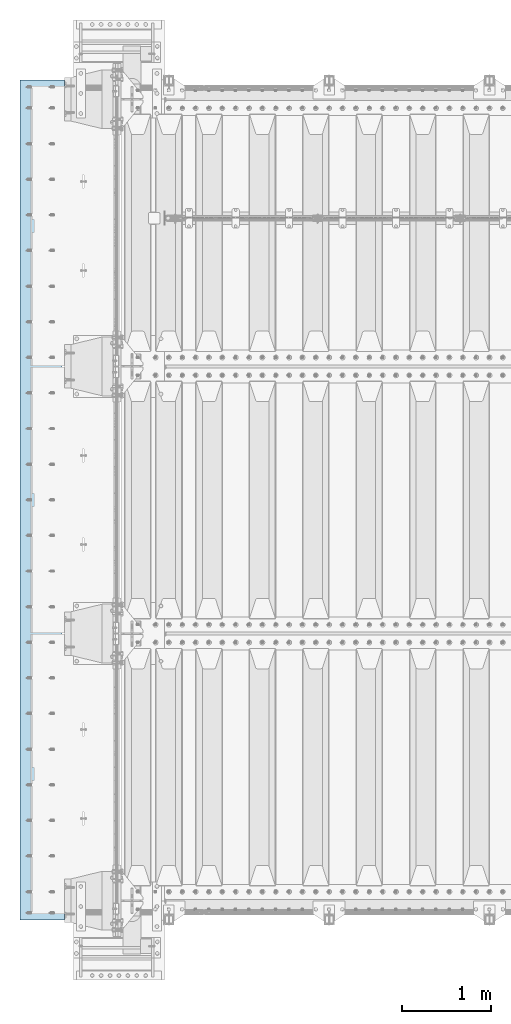
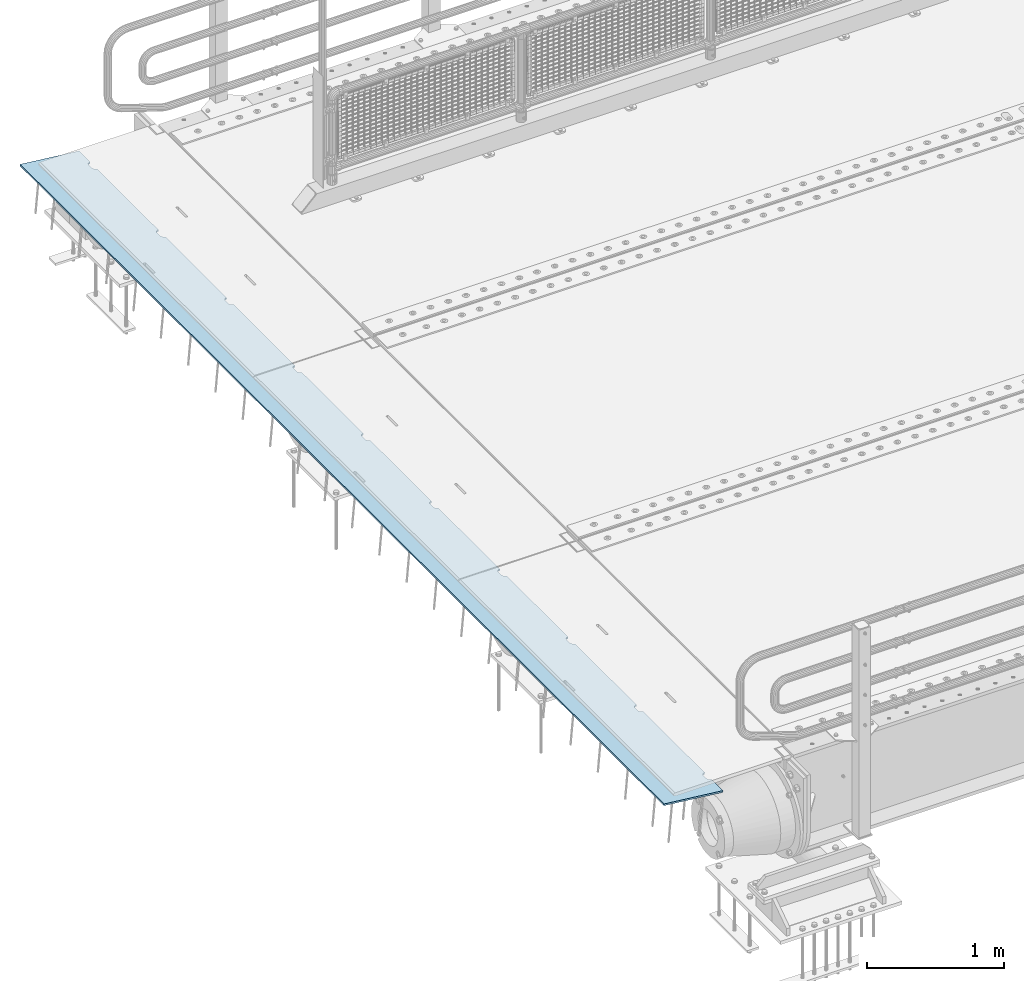
# One storey, part 192 of 247: 1 plate.
"""IFC2X3 building model written with IfcOpenShell, lengths in millimetres."""

from ifc_helpers import new_model, si_unit, frame, origin_with_axes, place, context, subcontext, project, spatial, faceted_brep, material, type_object, element, save


model = new_model("IFC2X3")

# Units and contexts
model_context = context("Model", 3, precision=1e-05, world=origin_with_axes())
body_context = subcontext(model_context, "Body", "Model", "MODEL_VIEW")
ifc_project = project(units=[si_unit("LENGTHUNIT", "METRE", prefix="MILLI"), si_unit("AREAUNIT", "SQUARE_METRE"), si_unit("VOLUMEUNIT", "CUBIC_METRE"), si_unit("MASSUNIT", "GRAM", prefix="KILO"), si_unit("TIMEUNIT", "SECOND"), si_unit("PLANEANGLEUNIT", "RADIAN"), si_unit("SOLIDANGLEUNIT", "STERADIAN"), si_unit("THERMODYNAMICTEMPERATUREUNIT", "DEGREE_CELSIUS"), si_unit("LUMINOUSINTENSITYUNIT", "LUMEN")], contexts=[model_context])

# Site, building, storey
site_placement = place(None, origin_with_axes())
site = spatial("IfcSite", under=ifc_project, at=site_placement, CompositionType="ELEMENT")
building_placement = place(site_placement, origin_with_axes())
building = spatial("IfcBuilding", under=site, at=building_placement, Name="Standard", CompositionType="ELEMENT")
storey_placement = place(building_placement, origin_with_axes())
storey = spatial("IfcBuildingStorey", under=building, at=storey_placement, Name="Undefined", CompositionType="ELEMENT", Elevation=0.0)

# Plate
ifc_material = material(Name="STEEL/S355N")
plate_type = type_object("IfcPlateType", PredefinedType="NOTDEFINED")
plate_placement = place(storey_placement, frame((-624.181254970226, -215.000000001889, -62.544823504668), z_axis=(-0.99402353270819, -9.99999997181678e-10, 0.109166003967953), x_axis=(0.0, 1.0, 0.0)))
element("IfcPlate", 1, at=plate_placement, inside=storey, type_object=plate_type, material=ifc_material, context=body_context, shape_type="Brep", body=[
    faceted_brep([(9165.000000001, -7.50000000000003, 7.55625608235277e-05), (9165.00000000271, 7.5, -1.22668097901624e-10), (9165.45576741755, 7.50000000000006, 5.20977563143788), (9165.45576741591, -7.50000000000003, 5.20977563143788), (9166.80922138939, 7.50000000000003, 10.260934599855), (9166.80922138776, -7.50000000000001, 10.260934599855), (9169.01923790417, 7.5, 15.0003302978881), (9169.01923790254, -7.50000000000003, 15.0003302978881), (9172.01866672842, 7.50000000000006, 19.283958585503), (9172.01866672678, -7.5, 19.2839585855029), (9175.71637173509, 7.50000000000003, 22.9816635848008), (9175.71637173345, -7.50000000000001, 22.9816635848008), (9180.00000002869, 7.5, 25.9810924005067), (9180.00000002705, -7.5, 25.9810924005067), (9184.73939573113, 7.50000000000006, 28.1911089058397), (9184.73939572949, -7.49999999999999, 28.1911089058398), (9189.79055470224, 7.50000000000003, 29.5445628676079), (9189.7905547006, -7.50000000000001, 29.5445628676079), (9195.00000003271, 7.5, 30.0003302720633), (9195.00000003107, -7.50000000000003, 30.0003302720631), (9235.00000003271, 7.5, 30.0003302323024), (9235.00000003107, -7.50000000000003, 30.0003302323023), (9240.20944536226, 7.50000000000006, 29.5445628174903), (9240.20944536062, -7.5, 29.5445628174903), (9245.26060433067, 7.50000000000006, 28.1911088456804), (9245.26060432903, -7.49999999999999, 28.1911088456804), (9250.00000002869, 7.50000000000003, 25.9810923309252), (9250.00000002705, -7.50000000000003, 25.9810923309251), (9254.28362831629, 7.50000000000006, 22.9816635067033), (9254.28362831465, -7.5, 22.9816635067034), (9257.98133331556, 7.5, 19.2839585000546), (9257.98133331392, -7.50000000000003, 19.2839585000545), (9260.98076213124, 7.50000000000003, 15.000330206477), (9260.9807621296, -7.50000000000001, 15.0003302064769), (9263.19077863654, 7.50000000000003, 10.2609345040502), (9263.19077863491, -7.50000000000003, 10.2609345040502), (9264.54423259828, 7.50000000000003, 5.20977553294267), (9264.54423259665, -7.50000000000003, 5.20977553294256), (9265.00000000107, -7.50000000000001, 0.000330202481677588), (9265.00000000271, 7.5, -1.24032339954283e-10), (8265.00000000107, -7.5, 0.00033219055490008), (8264.54423259665, -7.50000000000003, 5.20977752101589), (8264.54423259828, 7.50000000000003, 5.20977752101589), (8265.00000000271, 7.50000000000003, -1.10617293103132e-10), (8263.19077863491, -7.50000000000003, 10.2609364921234), (8263.19077863654, 7.50000000000003, 10.2609364921234), (8260.9807621296, -7.5, 15.0003321945503), (8260.98076213124, 7.5, 15.0003321945503), (8257.98133331392, -7.50000000000001, 19.2839604881278), (8257.98133331556, 7.5, 19.2839604881278), (8254.28362831465, -7.50000000000003, 22.9816654947765), (8254.28362831629, 7.5, 22.9816654947766), (8250.00000002705, -7.50000000000003, 25.9810943189984), (8250.00000002869, 7.50000000000003, 25.9810943189984), (8245.26060432903, -7.50000000000001, 28.1911108337537), (8245.26060433067, 7.5, 28.1911108337537), (8240.20944536062, -7.50000000000003, 29.5445648055636), (8240.20944536226, 7.5, 29.5445648055635), (8235.00000003107, -7.5, 30.0003322203756), (8235.00000003271, 7.5, 30.0003322203758), (8195.00000003107, -7.50000000000001, 30.0003322601366), (8195.00000003271, 7.5, 30.0003322601367), (8189.79055470061, -7.50000000000003, 29.5445648556812), (8189.79055470224, 7.5, 29.5445648556812), (8184.73939572949, -7.50000000000003, 28.1911108939131), (8184.73939573113, 7.5, 28.1911108939131), (8180.00000002705, -7.50000000000003, 25.98109438858), (8180.00000002869, 7.5, 25.98109438858), (8175.71637173346, -7.50000000000003, 22.981665572874), (8175.71637173509, 7.5, 22.981665572874), (8172.01866672678, -7.50000000000001, 19.2839605735763), (8172.01866672842, 7.5, 19.2839605735762), (8169.01923790254, -7.50000000000001, 15.0003322859613), (8169.01923790417, 7.50000000000003, 15.0003322859613), (8166.80922138775, -7.5, 10.2609365879283), (8166.80922138939, 7.50000000000003, 10.2609365879283), (8165.45576741591, -7.50000000000003, 5.20977761951133), (8165.45576741755, 7.50000000000003, 5.20977761951121), (8165.00000000105, -7.5, 0.000195259053839436), (8165.00000000271, 7.50000000000003, -1.09139364212751e-10), (7265.00000000107, -7.5, 0.000334178628463633), (7265.00000000271, 7.5, -9.70885594142601e-11), (7264.54423259665, -7.50000000000003, 5.20977950908934), (7264.54423259828, 7.50000000000003, 5.20977950908934), (7263.19077863491, -7.50000000000006, 10.2609384801968), (7263.19077863655, 7.50000000000003, 10.260938480197), (7260.9807621296, -7.50000000000003, 15.0003341826238), (7260.98076213124, 7.50000000000006, 15.0003341826236), (7257.98133331392, -7.50000000000003, 19.2839624762012), (7257.98133331556, 7.50000000000006, 19.2839624762013), (7254.28362831465, -7.50000000000003, 22.9816674828501), (7254.28362831629, 7.50000000000003, 22.9816674828501), (7250.00000002705, -7.50000000000004, 25.9810963070719), (7250.00000002869, 7.50000000000006, 25.9810963070719), (7245.26060432903, -7.50000000000001, 28.1911128218272), (7245.26060433067, 7.50000000000006, 28.1911128218271), (7240.20944536062, -7.50000000000003, 29.544566793637), (7240.20944536226, 7.50000000000006, 29.544566793637), (7235.00000003107, -7.50000000000006, 30.000334208449), (7235.00000003271, 7.50000000000006, 30.000334208449), (7195.00000003107, -7.50000000000004, 30.0003342482099), (7195.00000003271, 7.50000000000003, 30.0003342482099), (7189.79055470061, -7.50000000000004, 29.5445668437545), (7189.79055470224, 7.50000000000006, 29.5445668437545), (7184.73939572949, -7.50000000000003, 28.1911128819866), (7184.73939573113, 7.50000000000006, 28.1911128819863), (7180.00000002705, -7.50000000000003, 25.9810963766535), (7180.00000002869, 7.50000000000003, 25.9810963766533), (7175.71637173346, -7.50000000000003, 22.9816675609474), (7175.71637173509, 7.50000000000006, 22.9816675609475), (7172.01866672678, -7.50000000000003, 19.2839625616497), (7172.01866672842, 7.50000000000006, 19.2839625616497), (7169.01923790254, -7.50000000000003, 15.000334274035), (7169.01923790417, 7.5, 15.0003342740348), (7166.80922138775, -7.50000000000004, 10.2609385760016), (7166.80922138939, 7.50000000000006, 10.2609385760016), (7165.45576741591, -7.50000000000006, 5.20977960758455), (7165.45576741755, 7.50000000000003, 5.20977960758466), (7165.00000000106, -7.5, 0.000240574238773661), (7165.00000000271, 7.50000000000003, -9.58380041993223e-11), (6265.00000000107, -7.5, 0.000336166701572438), (6265.00000000271, 7.50000000000003, -8.3787199400831e-11), (6264.54423259665, -7.50000000000003, 5.20978149716257), (6264.54423259828, 7.5, 5.20978149716268), (6263.19077863491, -7.50000000000003, 10.2609404682702), (6263.19077863655, 7.49999999999997, 10.2609404682701), (6260.9807621296, -7.50000000000003, 15.0003361706968), (6260.98076213124, 7.5, 15.0003361706969), (6257.98133331392, -7.50000000000006, 19.2839644642745), (6257.98133331556, 7.49999999999997, 19.2839644642746), (6254.28362831465, -7.50000000000003, 22.9816694709234), (6254.28362831629, 7.5, 22.9816694709233), (6250.00000002705, -7.50000000000003, 25.9810982951451), (6250.00000002869, 7.5, 25.9810982951452), (6245.26060432903, -7.50000000000006, 28.1911148099003), (6245.26060433067, 7.49999999999997, 28.1911148099005), (6240.20944536062, -7.50000000000004, 29.5445687817104), (6240.20944536226, 7.5, 29.5445687817103), (6235.00000003107, -7.50000000000006, 30.0003361965223), (6235.00000003271, 7.5, 30.0003361965224), (6195.00000003107, -7.50000000000004, 30.0003362362833), (6195.00000003271, 7.5, 30.0003362362834), (6189.79055470061, -7.50000000000004, 29.544568831828), (6189.79055470224, 7.5, 29.5445688318279), (6184.73939572949, -7.50000000000006, 28.1911148700599), (6184.73939573113, 7.5, 28.1911148700599), (6180.00000002705, -7.50000000000006, 25.9810983647267), (6180.00000002869, 7.49999999999997, 25.9810983647268), (6175.71637173346, -7.50000000000006, 22.9816695490208), (6175.71637173509, 7.5, 22.9816695490209), (6172.01866672678, -7.50000000000004, 19.283964549723), (6172.01866672842, 7.49999999999997, 19.283964549723), (6169.01923790254, -7.50000000000006, 15.0003362621081), (6169.01923790417, 7.5, 15.0003362621081), (6166.80922138775, -7.50000000000003, 10.2609405640751), (6166.80922138939, 7.5, 10.260940564075), (6165.45576741591, -7.50000000000006, 5.209781595658), (6165.45576741755, 7.5, 5.209781595658), (6165.00000000106, -7.5, 0.000265084088027834), (6165.00000000271, 7.5, -8.24229573481716e-11), (5265.00000000107, -7.50000000000001, 0.000338154775022304), (5265.00000000271, 7.5, -7.02584657119587e-11), (5264.54423259665, -7.5, 5.2097834852359), (5264.54423259828, 7.5, 5.2097834852359), (5263.19077863491, -7.5, 10.2609424563434), (5263.19077863655, 7.5, 10.2609424563435), (5260.9807621296, -7.49999999999997, 15.0003381587702), (5260.98076213124, 7.5, 15.0003381587702), (5257.98133331392, -7.50000000000001, 19.2839664523478), (5257.98133331556, 7.5, 19.2839664523477), (5254.28362831465, -7.5, 22.9816714589966), (5254.28362831629, 7.5, 22.9816714589966), (5250.00000002705, -7.5, 25.9811002832184), (5250.00000002869, 7.49999999999994, 25.9811002832184), (5245.26060432903, -7.5, 28.1911167979737), (5245.26060433067, 7.5, 28.1911167979736), (5240.20944536062, -7.5, 29.5445707697836), (5240.20944536226, 7.5, 29.5445707697835), (5235.00000003107, -7.49999999999999, 30.0003381845955), (5235.00000003271, 7.5, 30.0003381845956), (5195.00000003107, -7.5, 30.0003382243565), (5195.00000003271, 7.5, 30.0003382243566), (5189.79055470061, -7.5, 29.5445708199011), (5189.79055470224, 7.5, 29.5445708199012), (5184.73939572949, -7.49999999999999, 28.1911168581331), (5184.73939573113, 7.5, 28.1911168581331), (5180.00000002705, -7.5, 25.9811003528), (5180.00000002869, 7.5, 25.9811003527999), (5175.71637173346, -7.49999999999999, 22.981671537094), (5175.71637173509, 7.5, 22.981671537094), (5172.01866672678, -7.5, 19.2839665377962), (5172.01866672842, 7.5, 19.2839665377962), (5169.01923790254, -7.5, 15.0003382501816), (5169.01923790417, 7.49999999999997, 15.0003382501815), (5166.80922138775, -7.5, 10.2609425521482), (5166.80922138939, 7.49999999999997, 10.2609425521483), (5165.45576741591, -7.5, 5.20978358373122), (5165.45576741755, 7.5, 5.20978358373122), (5165.00000000107, -7.5, 0.000280873017345584), (5165.00000000271, 7.5, -6.90079104970209e-11), (4265.00000000107, -7.5, 0.000340142848358482), (4265.00000000271, 7.5, -5.69571056985296e-11), (4264.54423259665, -7.49999999999997, 5.20978547330935), (4264.54423259828, 7.5, 5.20978547330935), (4263.19077863491, -7.5, 10.2609444444169), (4263.19077863655, 7.49999999999997, 10.2609444444169), (4260.9807621296, -7.5, 15.0003401468434), (4260.98076213124, 7.5, 15.0003401468435), (4257.98133331392, -7.5, 19.2839684404213), (4257.98133331556, 7.5, 19.2839684404213), (4254.28362831465, -7.49999999999999, 22.9816734470701), (4254.28362831629, 7.5, 22.98167344707), (4250.00000002705, -7.5, 25.9811022712919), (4250.00000002869, 7.5, 25.9811022712919), (4245.26060432903, -7.50000000000001, 28.1911187860471), (4245.26060433067, 7.5, 28.1911187860471), (4240.20944536062, -7.49999999999997, 29.5445727578571), (4240.20944536226, 7.5, 29.5445727578571), (4235.00000003107, -7.49999999999999, 30.0003401726691), (4235.00000003271, 7.5, 30.0003401726691), (4195.00000003107, -7.5, 30.00034021243), (4195.00000003271, 7.5, 30.00034021243), (4189.79055470061, -7.5, 29.5445728079746), (4189.79055470224, 7.5, 29.5445728079745), (4184.73939572949, -7.5, 28.1911188462066), (4184.73939573113, 7.5, 28.1911188462066), (4180.00000002705, -7.5, 25.9811023408735), (4180.00000002869, 7.5, 25.9811023408735), (4175.71637173346, -7.49999999999997, 22.9816735251674), (4175.71637173509, 7.5, 22.9816735251675), (4172.01866672678, -7.5, 19.2839685258698), (4172.01866672842, 7.5, 19.2839685258698), (4169.01923790254, -7.49999999999997, 15.0003402382549), (4169.01923790417, 7.5, 15.0003402382548), (4166.80922138775, -7.49999999999997, 10.2609445402217), (4166.80922138939, 7.5, 10.2609445402215), (4165.45576741591, -7.49999999999999, 5.20978557180456), (4165.45576741755, 7.5, 5.20978557180456), (4165.00000000107, -7.5, 0.000292184783234006), (4165.00000000271, 7.5, -5.57065504835919e-11), (3265.00000000107, -7.5, 0.000342130921694661), (3265.00000000271, 7.5, -4.35420588473789e-11), (3264.54423259665, -7.5, 5.20978746138258), (3264.54423259828, 7.49999999999994, 5.20978746138269), (3263.19077863491, -7.5, 10.2609464324901), (3263.19077863655, 7.49999999999997, 10.2609464324901), (3260.9807621296, -7.5, 15.0003421349169), (3260.98076213124, 7.5, 15.000342134917), (3257.98133331392, -7.50000000000003, 19.2839704284945), (3257.98133331556, 7.49999999999997, 19.2839704284945), (3254.28362831465, -7.50000000000001, 22.9816754351434), (3254.28362831629, 7.49999999999994, 22.9816754351433), (3250.00000002705, -7.5, 25.9811042593651), (3250.00000002869, 7.49999999999997, 25.9811042593651), (3245.26060432903, -7.5, 28.1911207741204), (3245.26060433067, 7.49999999999997, 28.1911207741204), (3240.20944536062, -7.50000000000003, 29.5445747459303), (3240.20944536226, 7.49999999999997, 29.5445747459304), (3235.00000003107, -7.5, 30.0003421607422), (3235.00000003271, 7.49999999999997, 30.0003421607423), (3195.00000003107, -7.5, 30.0003422005032), (3195.00000003271, 7.49999999999997, 30.0003422005033), (3189.79055470061, -7.5, 29.5445747960479), (3189.79055470224, 7.49999999999994, 29.5445747960479), (3184.73939572949, -7.5, 28.1911208342799), (3184.73939573113, 7.49999999999994, 28.1911208342798), (3180.00000002705, -7.49999999999997, 25.9811043289467), (3180.00000002869, 7.49999999999997, 25.9811043289467), (3175.71637173346, -7.5, 22.9816755132408), (3175.71637173509, 7.49999999999994, 22.9816755132408), (3172.01866672678, -7.50000000000003, 19.2839705139429), (3172.01866672842, 7.49999999999997, 19.283970513943), (3169.01923790254, -7.5, 15.0003422263283), (3169.01923790417, 7.49999999999997, 15.0003422263283), (3166.80922138775, -7.49999999999999, 10.260946528295), (3166.80922138939, 7.49999999999994, 10.260946528295), (3165.45576741591, -7.5, 5.2097875598779), (3165.45576741755, 7.49999999999994, 5.20978755987801), (3165.00000000107, -7.5, 0.000300893983194328), (3165.00000000271, 7.5, -4.22915036324412e-11), (2265.00000000107, -7.5, 0.00034411899503084), (2265.00000000271, 7.5, -3.02406988339499e-11), (2264.54423259665, -7.50000000000003, 5.20978944945591), (2264.54423259828, 7.5, 5.20978944945603), (2263.19077863491, -7.50000000000003, 10.2609484205635), (2263.19077863655, 7.49999999999997, 10.2609484205634), (2260.9807621296, -7.50000000000003, 15.0003441229902), (2260.98076213124, 7.49999999999997, 15.0003441229902), (2257.98133331392, -7.5, 19.283972416568), (2257.98133331556, 7.5, 19.2839724165678), (2254.28362831465, -7.5, 22.9816774232166), (2254.28362831629, 7.49999999999997, 22.9816774232168), (2250.00000002705, -7.50000000000003, 25.9811062474384), (2250.00000002869, 7.5, 25.9811062474386), (2245.26060432903, -7.50000000000001, 28.1911227621937), (2245.26060433067, 7.5, 28.1911227621938), (2240.20944536062, -7.50000000000003, 29.5445767340037), (2240.20944536226, 7.49999999999997, 29.5445767340036), (2235.00000003107, -7.50000000000003, 30.0003441488157), (2235.00000003271, 7.5, 30.0003441488158), (2195.00000003107, -7.50000000000003, 30.0003441885766), (2195.00000003271, 7.5, 30.0003441885767), (2189.79055470061, -7.5, 29.5445767841211), (2189.79055470224, 7.49999999999997, 29.5445767841211), (2184.73939572949, -7.50000000000003, 28.191122822353), (2184.73939573113, 7.5, 28.1911228223531), (2180.00000002705, -7.50000000000003, 25.9811063170199), (2180.00000002869, 7.49999999999997, 25.9811063170199), (2175.71637173346, -7.50000000000003, 22.9816775013139), (2175.71637173509, 7.49999999999997, 22.9816775013139), (2172.01866672678, -7.50000000000003, 19.2839725020162), (2172.01866672842, 7.49999999999997, 19.2839725020161), (2169.01923790254, -7.50000000000003, 15.0003442144015), (2169.01923790417, 7.5, 15.0003442144016), (2166.80922138775, -7.50000000000003, 10.2609485163682), (2166.80922138939, 7.5, 10.2609485163682), (2165.45576741591, -7.50000000000003, 5.20978954795123), (2165.45576741755, 7.5, 5.20978954795112), (2165.00000000107, -7.49999999999999, 0.000307956857113822), (2165.00000000271, 7.5, -2.89901436190121e-11), (1265.00000000107, -7.49999999999999, 0.000346107068367019), (1265.00000000271, 7.5, -1.69393388205208e-11), (1264.54423259665, -7.50000000000003, 5.20979143752925), (1264.54423259828, 7.5, 5.20979143752925), (1263.19077863491, -7.50000000000003, 10.2609504086367), (1263.19077863655, 7.5, 10.2609504086369), (1260.9807621296, -7.5, 15.0003461110638), (1260.98076213124, 7.5, 15.0003461110637), (1257.98133331392, -7.50000000000003, 19.2839744046413), (1257.98133331556, 7.5, 19.2839744046413), (1254.28362831465, -7.5, 22.9816794112901), (1254.28362831629, 7.5, 22.9816794112901), (1250.00000002705, -7.50000000000001, 25.9811082355119), (1250.00000002869, 7.5, 25.9811082355118), (1245.26060432903, -7.5, 28.1911247502671), (1245.26060433067, 7.49999999999997, 28.191124750267), (1240.20944536062, -7.5, 29.5445787220769), (1240.20944536226, 7.5, 29.5445787220771), (1235.00000003107, -7.50000000000003, 30.000346136889), (1235.00000003271, 7.5, 30.000346136889), (1195.00000003107, -7.50000000000003, 30.0003461766499), (1195.00000003271, 7.5, 30.0003461766499), (1189.79055470061, -7.50000000000004, 29.5445787721945), (1189.79055470224, 7.5, 29.5445787721945), (1184.73939572949, -7.5, 28.1911248104266), (1184.73939573113, 7.5, 28.1911248104265), (1180.00000002705, -7.5, 25.9811083050935), (1180.00000002869, 7.5, 25.9811083050934), (1175.71637173346, -7.50000000000001, 22.9816794893875), (1175.71637173509, 7.5, 22.9816794893875), (1172.01866672678, -7.5, 19.2839744900898), (1172.01866672842, 7.5, 19.2839744900897), (1169.01923790254, -7.50000000000003, 15.0003462024749), (1169.01923790417, 7.5, 15.0003462024748), (1166.80922138775, -7.50000000000003, 10.2609505044417), (1166.80922138939, 7.5, 10.2609505044417), (1165.45576741591, -7.50000000000003, 5.20979153602457), (1165.45576741755, 7.5, 5.20979153602468), (1165.00000000107, -7.49999999999999, 0.0003139123003848), (1165.00000000271, 7.5, -1.55750967678614e-11), (265.00000000107, -7.5, 0.000348095141703197), (265.000000002708, 7.5, -3.41060513164848e-12), (264.544232596646, -7.5, 5.20979342560258), (264.544232598283, 7.5, 5.2097934256027), (263.190778634908, -7.5, 10.2609523967103), (263.190778636546, 7.5, 10.2609523967101), (260.980762129603, -7.5, 15.0003480991369), (260.980762131241, 7.5, 15.000348099137), (257.981333313923, -7.5, 19.2839763927146), (257.981333315561, 7.5, 19.2839763927147), (254.283628314648, -7.50000000000001, 22.9816813993634), (254.283628316285, 7.5, 22.9816813993634), (250.000000027051, -7.50000000000001, 25.9811102235851), (250.000000028689, 7.5, 25.9811102235852), (245.260604329031, -7.50000000000001, 28.1911267383404), (245.260604330669, 7.5, 28.1911267383405), (240.209445360622, -7.5, 29.5445807101504), (240.20944536226, 7.49999999999997, 29.5445807101504), (235.00000003107, -7.50000000000001, 30.0003481249624), (235.000000032708, 7.5, 30.0003481249624), (195.00000003107, -7.5, 30.0003481647233), (195.000000032708, 7.5, 30.0003481647233), (189.790554700606, -7.5, 29.5445807602679), (189.790554702244, 7.5, 29.5445807602678), (184.739395729491, -7.50000000000001, 28.1911267984998), (184.739395731128, 7.5, 28.1911267984998), (180.000000027051, -7.50000000000001, 25.9811102931666), (180.000000028688, 7.5, 25.9811102931667), (175.716371733455, -7.5, 22.9816814774607), (175.716371735093, 7.5, 22.9816814774608), (172.018666726784, -7.5, 19.283976478163), (172.018666728422, 7.5, 19.2839764781629), (169.019237902537, -7.5, 15.0003481905482), (169.019237904174, 7.5, 15.0003481905483), (166.809221387753, -7.5, 10.260952492515), (166.809221389391, 7.5, 10.2609524925149), (165.455767415913, -7.5, 5.2097935240979), (165.455767417551, 7.5, 5.2097935240979), (165.00000000107, -7.5, -2.1600499167107e-12), (165.000000002708, 7.5, -2.1600499167107e-12), (0.0, -7.49999999999999, 0.0), (0.0, 7.5, 0.0), (7.8152567084544e-08, -7.5, 500.00244140625), (7.8152567084544e-08, 7.5, 500.00244140625), (9430.00000000299, -7.49999999999999, 500.002380371094), (9430.00000000299, 7.5, 500.002380371094), (9430.0, -7.5, -1.26306076708715e-10), (9430.0, 7.5, -1.26192389870994e-10)], [[[0, 1, 2, 3]], [[3, 2, 4, 5]], [[5, 4, 6, 7]], [[7, 6, 8, 9]], [[9, 8, 10, 11]], [[11, 10, 12, 13]], [[13, 12, 14, 15]], [[15, 14, 16, 17]], [[17, 16, 18, 19]], [[19, 18, 20, 21]], [[21, 20, 22, 23]], [[23, 22, 24, 25]], [[25, 24, 26, 27]], [[27, 26, 28, 29]], [[29, 28, 30, 31]], [[31, 30, 32, 33]], [[33, 32, 34, 35]], [[35, 34, 36, 37]], [[38, 37, 36, 39]], [[40, 41, 42, 43]], [[44, 45, 42, 41]], [[46, 47, 45, 44]], [[48, 49, 47, 46]], [[50, 51, 49, 48]], [[52, 53, 51, 50]], [[54, 55, 53, 52]], [[56, 57, 55, 54]], [[58, 59, 57, 56]], [[60, 61, 59, 58]], [[62, 63, 61, 60]], [[64, 65, 63, 62]], [[66, 67, 65, 64]], [[68, 69, 67, 66]], [[70, 71, 69, 68]], [[72, 73, 71, 70]], [[74, 75, 73, 72]], [[76, 77, 75, 74]], [[78, 79, 77, 76]], [[80, 81, 79, 78]], [[80, 82, 83, 81]], [[84, 85, 83, 82]], [[86, 87, 85, 84]], [[88, 89, 87, 86]], [[90, 91, 89, 88]], [[92, 93, 91, 90]], [[94, 95, 93, 92]], [[96, 97, 95, 94]], [[98, 99, 97, 96]], [[100, 101, 99, 98]], [[102, 103, 101, 100]], [[104, 105, 103, 102]], [[106, 107, 105, 104]], [[108, 109, 107, 106]], [[110, 111, 109, 108]], [[112, 113, 111, 110]], [[114, 115, 113, 112]], [[116, 117, 115, 114]], [[118, 119, 117, 116]], [[120, 121, 119, 118]], [[120, 122, 123, 121]], [[124, 125, 123, 122]], [[126, 127, 125, 124]], [[128, 129, 127, 126]], [[130, 131, 129, 128]], [[132, 133, 131, 130]], [[134, 135, 133, 132]], [[136, 137, 135, 134]], [[138, 139, 137, 136]], [[140, 141, 139, 138]], [[142, 143, 141, 140]], [[144, 145, 143, 142]], [[146, 147, 145, 144]], [[148, 149, 147, 146]], [[150, 151, 149, 148]], [[152, 153, 151, 150]], [[154, 155, 153, 152]], [[156, 157, 155, 154]], [[158, 159, 157, 156]], [[160, 161, 159, 158]], [[160, 162, 163, 161]], [[164, 165, 163, 162]], [[166, 167, 165, 164]], [[168, 169, 167, 166]], [[170, 171, 169, 168]], [[172, 173, 171, 170]], [[174, 175, 173, 172]], [[176, 177, 175, 174]], [[178, 179, 177, 176]], [[180, 181, 179, 178]], [[182, 183, 181, 180]], [[184, 185, 183, 182]], [[186, 187, 185, 184]], [[188, 189, 187, 186]], [[190, 191, 189, 188]], [[192, 193, 191, 190]], [[194, 195, 193, 192]], [[196, 197, 195, 194]], [[198, 199, 197, 196]], [[200, 201, 199, 198]], [[200, 202, 203, 201]], [[204, 205, 203, 202]], [[206, 207, 205, 204]], [[208, 209, 207, 206]], [[210, 211, 209, 208]], [[212, 213, 211, 210]], [[214, 215, 213, 212]], [[216, 217, 215, 214]], [[218, 219, 217, 216]], [[220, 221, 219, 218]], [[222, 223, 221, 220]], [[224, 225, 223, 222]], [[226, 227, 225, 224]], [[228, 229, 227, 226]], [[230, 231, 229, 228]], [[232, 233, 231, 230]], [[234, 235, 233, 232]], [[236, 237, 235, 234]], [[238, 239, 237, 236]], [[240, 241, 239, 238]], [[240, 242, 243, 241]], [[244, 245, 243, 242]], [[246, 247, 245, 244]], [[248, 249, 247, 246]], [[250, 251, 249, 248]], [[252, 253, 251, 250]], [[254, 255, 253, 252]], [[256, 257, 255, 254]], [[258, 259, 257, 256]], [[260, 261, 259, 258]], [[262, 263, 261, 260]], [[264, 265, 263, 262]], [[266, 267, 265, 264]], [[268, 269, 267, 266]], [[270, 271, 269, 268]], [[272, 273, 271, 270]], [[274, 275, 273, 272]], [[276, 277, 275, 274]], [[278, 279, 277, 276]], [[280, 281, 279, 278]], [[280, 282, 283, 281]], [[284, 285, 283, 282]], [[286, 287, 285, 284]], [[288, 289, 287, 286]], [[290, 291, 289, 288]], [[292, 293, 291, 290]], [[294, 295, 293, 292]], [[296, 297, 295, 294]], [[298, 299, 297, 296]], [[300, 301, 299, 298]], [[302, 303, 301, 300]], [[304, 305, 303, 302]], [[306, 307, 305, 304]], [[308, 309, 307, 306]], [[310, 311, 309, 308]], [[312, 313, 311, 310]], [[314, 315, 313, 312]], [[316, 317, 315, 314]], [[318, 319, 317, 316]], [[320, 321, 319, 318]], [[320, 322, 323, 321]], [[324, 325, 323, 322]], [[326, 327, 325, 324]], [[328, 329, 327, 326]], [[330, 331, 329, 328]], [[332, 333, 331, 330]], [[334, 335, 333, 332]], [[336, 337, 335, 334]], [[338, 339, 337, 336]], [[340, 341, 339, 338]], [[342, 343, 341, 340]], [[344, 345, 343, 342]], [[346, 347, 345, 344]], [[348, 349, 347, 346]], [[350, 351, 349, 348]], [[352, 353, 351, 350]], [[354, 355, 353, 352]], [[356, 357, 355, 354]], [[358, 359, 357, 356]], [[360, 361, 359, 358]], [[360, 362, 363, 361]], [[364, 365, 363, 362]], [[366, 367, 365, 364]], [[368, 369, 367, 366]], [[370, 371, 369, 368]], [[372, 373, 371, 370]], [[374, 375, 373, 372]], [[376, 377, 375, 374]], [[378, 379, 377, 376]], [[380, 381, 379, 378]], [[382, 383, 381, 380]], [[384, 385, 383, 382]], [[386, 387, 385, 384]], [[388, 389, 387, 386]], [[390, 391, 389, 388]], [[392, 393, 391, 390]], [[394, 395, 393, 392]], [[396, 397, 395, 394]], [[398, 399, 397, 396]], [[400, 401, 399, 398]], [[400, 402, 403, 401]], [[402, 404, 405, 403]], [[404, 406, 407, 405]], [[407, 406, 38, 39]], [[34, 32, 30, 28, 26, 24, 22, 20, 18, 16, 14, 12, 10, 8, 6, 4, 2, 1, 43, 42, 45, 47, 49, 51, 53, 55, 57, 59, 61, 63, 65, 67, 69, 71, 73, 75, 77, 79, 81, 83, 85, 87, 89, 91, 93, 95, 97, 99, 101, 103, 105, 107, 109, 111, 113, 115, 117, 119, 121, 123, 125, 127, 129, 131, 133, 135, 137, 139, 141, 143, 145, 147, 149, 151, 153, 155, 157, 159, 161, 163, 165, 167, 169, 171, 173, 175, 177, 179, 181, 183, 185, 187, 189, 191, 193, 195, 197, 199, 201, 203, 205, 207, 209, 211, 213, 215, 217, 219, 221, 223, 225, 227, 229, 231, 233, 235, 237, 239, 241, 243, 245, 247, 249, 251, 253, 255, 257, 259, 261, 263, 265, 267, 269, 271, 273, 275, 277, 279, 281, 283, 285, 287, 289, 291, 293, 295, 297, 299, 301, 303, 305, 307, 309, 311, 313, 315, 317, 319, 321, 323, 325, 327, 329, 331, 333, 335, 337, 339, 341, 343, 345, 347, 349, 351, 353, 355, 357, 359, 361, 363, 365, 367, 369, 371, 373, 375, 377, 379, 381, 383, 385, 387, 389, 391, 393, 395, 397, 399, 401, 403, 405, 407, 39, 36]], [[40, 43, 1, 0]], [[406, 404, 402, 400, 398, 396, 394, 392, 390, 388, 386, 384, 382, 380, 378, 376, 374, 372, 370, 368, 366, 364, 362, 360, 358, 356, 354, 352, 350, 348, 346, 344, 342, 340, 338, 336, 334, 332, 330, 328, 326, 324, 322, 320, 318, 316, 314, 312, 310, 308, 306, 304, 302, 300, 298, 296, 294, 292, 290, 288, 286, 284, 282, 280, 278, 276, 274, 272, 270, 268, 266, 264, 262, 260, 258, 256, 254, 252, 250, 248, 246, 244, 242, 240, 238, 236, 234, 232, 230, 228, 226, 224, 222, 220, 218, 216, 214, 212, 210, 208, 206, 204, 202, 200, 198, 196, 194, 192, 190, 188, 186, 184, 182, 180, 178, 176, 174, 172, 170, 168, 166, 164, 162, 160, 158, 156, 154, 152, 150, 148, 146, 144, 142, 140, 138, 136, 134, 132, 130, 128, 126, 124, 122, 120, 118, 116, 114, 112, 110, 108, 106, 104, 102, 100, 98, 96, 94, 92, 90, 88, 86, 84, 82, 80, 78, 76, 74, 72, 70, 68, 66, 64, 62, 60, 58, 56, 54, 52, 50, 48, 46, 44, 41, 40, 0, 3, 5, 7, 9, 11, 13, 15, 17, 19, 21, 23, 25, 27, 29, 31, 33, 35, 37, 38]]]),
])

save(model, "model.ifc")
